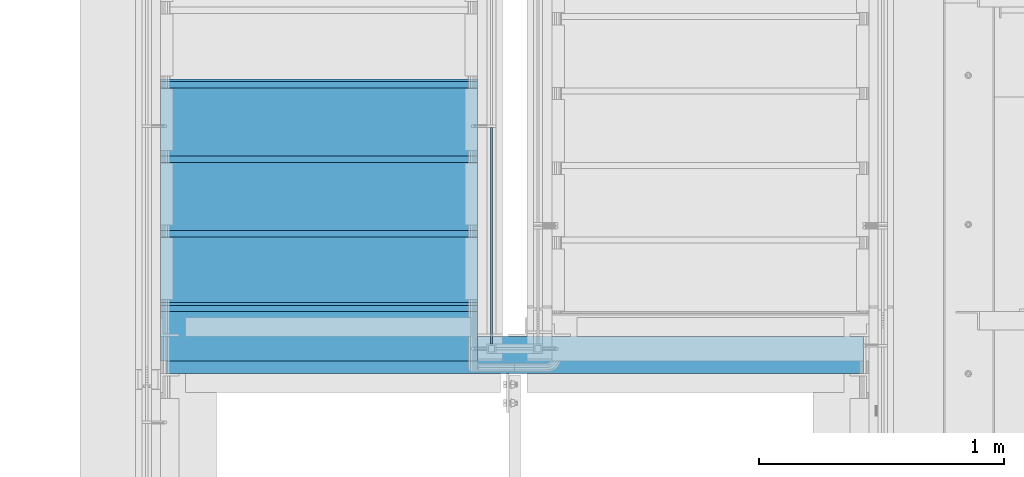
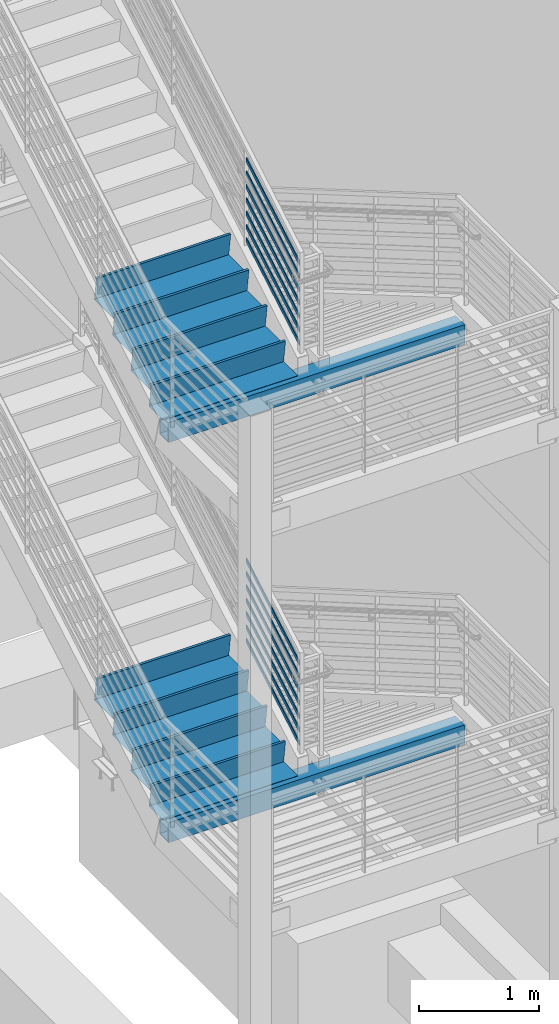
# One storey, part 753 of 1179: 14 members, 10 beams, 6 elements without a shape of their own.
"""IFC2X3 building model written with IfcOpenShell, lengths in millimetres."""

from ifc_helpers import new_model, si_unit, frame, origin_with_axes, place, context, subcontext, project, spatial, faceted_brep, material, type_object, element, aggregate, save


model = new_model("IFC2X3")

# Units and contexts
model_context = context("Model", 3, precision=1e-05, world=origin_with_axes())
body_context = subcontext(model_context, "Body", "Model", "MODEL_VIEW")
ifc_project = project(units=[si_unit("LENGTHUNIT", "METRE", prefix="MILLI"), si_unit("AREAUNIT", "SQUARE_METRE"), si_unit("VOLUMEUNIT", "CUBIC_METRE"), si_unit("MASSUNIT", "GRAM", prefix="KILO"), si_unit("TIMEUNIT", "SECOND"), si_unit("PLANEANGLEUNIT", "RADIAN"), si_unit("SOLIDANGLEUNIT", "STERADIAN"), si_unit("THERMODYNAMICTEMPERATUREUNIT", "DEGREE_CELSIUS"), si_unit("LUMINOUSINTENSITYUNIT", "LUMEN")], contexts=[model_context])

# Site, building, storey
site_placement = place(None, origin_with_axes())
site = spatial("IfcSite", under=ifc_project, at=site_placement, CompositionType="ELEMENT")
building_placement = place(site_placement, origin_with_axes())
building = spatial("IfcBuilding", under=site, at=building_placement, Name="Undefined", CompositionType="ELEMENT")
storey_placement = place(building_placement, origin_with_axes())
storey = spatial("IfcBuildingStorey", under=building, at=storey_placement, Name="Undefined", CompositionType="ELEMENT", Elevation=0.0)

# Assembly, members
assembly_1_placement = place(storey_placement, origin_with_axes())
assembly_1 = element("IfcElementAssembly", 1, at=assembly_1_placement, inside=storey, Name="GUARDRAIL", AssemblyPlace="NOTDEFINED", PredefinedType="RIGID_FRAME")
ifc_material_1 = material(Name="STEEL/A36")
member_type = type_object("IfcMemberType", PredefinedType="NOTDEFINED")
member_1_placement = place(assembly_1_placement, frame((-1847.85000153055, 32657.0650348949, 6932.20421216632), z_axis=(0.0, -0.503851349994406, 0.86379037799041), x_axis=(0.0, -0.86379037799041, -0.503851349994406)))
member_1 = element("IfcMember", 2, at=member_1_placement, type_object=member_type, material=ifc_material_1, Name="PLATE", context=body_context, shape_type="Brep", body=[
    faceted_brep([(27.7373273120902, 4.76250000000005, -19.0499999999865), (5.51349046009636, 4.76250000000005, 19.0499999999811), (1031.63336768552, 4.76250000000005, 19.0499999996719), (1053.85720453752, 4.76250000000005, -19.0500000002939), (5.51349046009636, -4.76250000000005, 19.0499999999811), (1031.63336768552, -4.76250000000005, 19.0499999996719), (27.7373273120902, -4.76250000000005, -19.0499999999865), (1053.85720453752, -4.76250000000005, -19.0500000002939)], [[[0, 1, 2, 3]], [[1, 4, 5, 2]], [[4, 6, 7, 5]], [[6, 0, 3, 7]], [[5, 7, 3, 2]], [[6, 4, 1, 0]]]),
])
member_2_placement = place(assembly_1_placement, frame((-1847.85000153055, 32657.0650348949, 7068.38772184206), z_axis=(0.0, -0.503851349994406, 0.86379037799041), x_axis=(0.0, -0.86379037799041, -0.503851349994406)))
member_2 = element("IfcMember", 3, at=member_2_placement, type_object=member_type, material=ifc_material_1, Name="PLATE", context=body_context, shape_type="Brep", body=[
    faceted_brep([(27.7373273120902, 4.76250000000005, -19.0499999999865), (5.51349046009636, 4.76250000000005, 19.0499999999811), (1031.63336768552, 4.76250000000005, 19.0499999996719), (1053.85720453752, 4.76250000000005, -19.0500000002939), (5.51349046009636, -4.76250000000005, 19.0499999999811), (1031.63336768552, -4.76250000000005, 19.0499999996719), (27.7373273120902, -4.76250000000005, -19.0499999999865), (1053.85720453752, -4.76250000000005, -19.0500000002939)], [[[0, 1, 2, 3]], [[1, 4, 5, 2]], [[4, 6, 7, 5]], [[6, 0, 3, 7]], [[5, 7, 3, 2]], [[6, 4, 1, 0]]]),
])
member_3_placement = place(assembly_1_placement, frame((-1847.85000153055, 32657.0650348948, 7204.57123151781), z_axis=(0.0, -0.503851349994406, 0.86379037799041), x_axis=(0.0, -0.86379037799041, -0.503851349994406)))
member_3 = element("IfcMember", 4, at=member_3_placement, type_object=member_type, material=ifc_material_1, Name="PLATE", context=body_context, shape_type="Brep", body=[
    faceted_brep([(27.7373273120902, 4.76250000000005, -19.0499999999865), (5.51349046009636, 4.76250000000005, 19.0499999999811), (1031.63336768552, 4.76250000000005, 19.0499999996719), (1053.85720453752, 4.76250000000005, -19.0500000002939), (5.51349046009636, -4.76250000000005, 19.0499999999811), (1031.63336768552, -4.76250000000005, 19.0499999996719), (27.7373273120902, -4.76250000000005, -19.0499999999865), (1053.85720453752, -4.76250000000005, -19.0500000002939)], [[[0, 1, 2, 3]], [[1, 4, 5, 2]], [[4, 6, 7, 5]], [[6, 0, 3, 7]], [[5, 7, 3, 2]], [[6, 4, 1, 0]]]),
])
member_4_placement = place(assembly_1_placement, frame((-1847.85000153055, 32657.0650348948, 7340.75474119355), z_axis=(0.0, -0.503851349994406, 0.86379037799041), x_axis=(0.0, -0.86379037799041, -0.503851349994406)))
member_4 = element("IfcMember", 5, at=member_4_placement, type_object=member_type, material=ifc_material_1, Name="PLATE", context=body_context, shape_type="Brep", body=[
    faceted_brep([(27.7373273120902, 4.76250000000005, -19.0499999999865), (5.51349046009636, 4.76250000000005, 19.0499999999811), (1031.63336768552, 4.76250000000005, 19.0499999996719), (1053.85720453752, 4.76250000000005, -19.0500000002939), (5.51349046009636, -4.76250000000005, 19.0499999999811), (1031.63336768552, -4.76250000000005, 19.0499999996719), (27.7373273120902, -4.76250000000005, -19.0499999999865), (1053.85720453752, -4.76250000000005, -19.0500000002939)], [[[0, 1, 2, 3]], [[1, 4, 5, 2]], [[4, 6, 7, 5]], [[6, 0, 3, 7]], [[5, 7, 3, 2]], [[6, 4, 1, 0]]]),
])
member_5_placement = place(assembly_1_placement, frame((-1847.85000153055, 32657.0650348949, 7476.93825086929), z_axis=(0.0, -0.503851349994406, 0.86379037799041), x_axis=(0.0, -0.86379037799041, -0.503851349994406)))
member_5 = element("IfcMember", 6, at=member_5_placement, type_object=member_type, material=ifc_material_1, Name="PLATE", context=body_context, shape_type="Brep", body=[
    faceted_brep([(27.7373273120902, 4.76250000000005, -19.0499999999865), (5.51349046009636, 4.76250000000005, 19.0499999999811), (1031.63336768552, 4.76250000000005, 19.0499999996719), (1053.85720453752, 4.76250000000005, -19.0500000002939), (5.51349046009636, -4.76250000000005, 19.0499999999811), (1031.63336768552, -4.76250000000005, 19.0499999996719), (27.7373273120902, -4.76250000000005, -19.0499999999865), (1053.85720453752, -4.76250000000005, -19.0500000002939)], [[[0, 1, 2, 3]], [[1, 4, 5, 2]], [[4, 6, 7, 5]], [[6, 0, 3, 7]], [[5, 7, 3, 2]], [[6, 4, 1, 0]]]),
])
member_6_placement = place(assembly_1_placement, frame((-1847.85000153055, 32657.065034895, 7613.12176054373), z_axis=(0.0, -0.503851349994406, 0.86379037799041), x_axis=(0.0, -0.86379037799041, -0.503851349994406)))
member_6 = element("IfcMember", 7, at=member_6_placement, type_object=member_type, material=ifc_material_1, Name="PLATE", context=body_context, shape_type="Brep", body=[
    faceted_brep([(27.7373273120902, 4.76250000000005, -19.0499999999865), (5.51349046009636, 4.76250000000005, 19.0499999999811), (1031.63336768552, 4.76250000000005, 19.0499999996719), (1053.85720453752, 4.76250000000005, -19.0500000002939), (5.51349046009636, -4.76250000000005, 19.0499999999811), (1031.63336768552, -4.76250000000005, 19.0499999996719), (27.7373273120902, -4.76250000000005, -19.0499999999865), (1053.85720453752, -4.76250000000005, -19.0500000002939)], [[[0, 1, 2, 3]], [[1, 4, 5, 2]], [[4, 6, 7, 5]], [[6, 0, 3, 7]], [[5, 7, 3, 2]], [[6, 4, 1, 0]]]),
])
member_7_placement = place(assembly_1_placement, frame((-1847.85000153055, 32657.0650348959, 7749.30527021945), z_axis=(0.0, -0.503851349994406, 0.86379037799041), x_axis=(0.0, -0.86379037799041, -0.503851349994406)))
member_7 = element("IfcMember", 8, at=member_7_placement, type_object=member_type, material=ifc_material_1, Name="PLATE", context=body_context, shape_type="Brep", body=[
    faceted_brep([(27.7373273120902, 4.76250000000005, -19.0499999999865), (5.51349046009636, 4.76250000000005, 19.0499999999811), (1031.63336768552, 4.76250000000005, 19.0499999996719), (1053.85720453752, 4.76250000000005, -19.0500000002939), (5.51349046009636, -4.76250000000005, 19.0499999999811), (1031.63336768552, -4.76250000000005, 19.0499999996719), (27.7373273120902, -4.76250000000005, -19.0499999999865), (1053.85720453752, -4.76250000000005, -19.0500000002939)], [[[0, 1, 2, 3]], [[1, 4, 5, 2]], [[4, 6, 7, 5]], [[6, 0, 3, 7]], [[5, 7, 3, 2]], [[6, 4, 1, 0]]]),
])
aggregate(assembly_1, [member_1, member_2, member_3, member_4, member_5, member_6, member_7])

assembly_2_placement = place(storey_placement, origin_with_axes())
assembly_2 = element("IfcElementAssembly", 9, at=assembly_2_placement, inside=storey, Name="GUARDRAIL", AssemblyPlace="NOTDEFINED", PredefinedType="RIGID_FRAME")
member_8_placement = place(assembly_2_placement, frame((-1847.85000076555, 32657.0119717504, 2855.03882129838), z_axis=(0.0, -0.501065882891537, 0.865409140812671), x_axis=(0.0, -0.86540914081267, -0.501065882891538)))
member_8 = element("IfcMember", 10, at=member_8_placement, type_object=member_type, material=ifc_material_1, Name="PLATE", context=body_context, shape_type="Brep", body=[
    faceted_brep([(27.5628128089447, 4.76250000000005, -19.0499999999756), (5.50317738577724, 4.76250000000005, 19.0499999999902), (1029.7056333605, 4.76250000000005, 19.0500000004522), (1051.76526878367, 4.76250000000005, -19.0499999995136), (5.50317738577724, -4.76250000000005, 19.0499999999902), (1029.7056333605, -4.76250000000005, 19.0500000004522), (27.5628128089447, -4.76250000000005, -19.0499999999756), (1051.76526878367, -4.76250000000005, -19.0499999995136)], [[[0, 1, 2, 3]], [[1, 4, 5, 2]], [[4, 6, 7, 5]], [[6, 0, 3, 7]], [[5, 7, 3, 2]], [[6, 4, 1, 0]]]),
])
member_9_placement = place(assembly_2_placement, frame((-1847.85000076555, 32657.0119717505, 2991.13924026293), z_axis=(0.0, -0.501065882891537, 0.865409140812671), x_axis=(0.0, -0.86540914081267, -0.501065882891538)))
member_9 = element("IfcMember", 11, at=member_9_placement, type_object=member_type, material=ifc_material_1, Name="PLATE", context=body_context, shape_type="Brep", body=[
    faceted_brep([(27.5628128089447, 4.76250000000005, -19.0499999999756), (5.50317738577724, 4.76250000000005, 19.0499999999902), (1029.7056333605, 4.76250000000005, 19.0500000004522), (1051.76526878367, 4.76250000000005, -19.0499999995136), (5.50317738577724, -4.76250000000005, 19.0499999999902), (1029.7056333605, -4.76250000000005, 19.0500000004522), (27.5628128089447, -4.76250000000005, -19.0499999999756), (1051.76526878367, -4.76250000000005, -19.0499999995136)], [[[0, 1, 2, 3]], [[1, 4, 5, 2]], [[4, 6, 7, 5]], [[6, 0, 3, 7]], [[5, 7, 3, 2]], [[6, 4, 1, 0]]]),
])
member_10_placement = place(assembly_2_placement, frame((-1847.85000076555, 32657.0119717504, 3127.2396592274), z_axis=(0.0, -0.501065882891537, 0.865409140812671), x_axis=(0.0, -0.86540914081267, -0.501065882891538)))
member_10 = element("IfcMember", 12, at=member_10_placement, type_object=member_type, material=ifc_material_1, Name="PLATE", context=body_context, shape_type="Brep", body=[
    faceted_brep([(27.5628128089447, 4.76250000000005, -19.0499999999756), (5.50317738577724, 4.76250000000005, 19.0499999999902), (1029.7056333605, 4.76250000000005, 19.0500000004522), (1051.76526878367, 4.76250000000005, -19.0499999995136), (5.50317738577724, -4.76250000000005, 19.0499999999902), (1029.7056333605, -4.76250000000005, 19.0500000004522), (27.5628128089447, -4.76250000000005, -19.0499999999756), (1051.76526878367, -4.76250000000005, -19.0499999995136)], [[[0, 1, 2, 3]], [[1, 4, 5, 2]], [[4, 6, 7, 5]], [[6, 0, 3, 7]], [[5, 7, 3, 2]], [[6, 4, 1, 0]]]),
])
member_11_placement = place(assembly_2_placement, frame((-1847.85000076555, 32657.0119717505, 3263.34007819193), z_axis=(0.0, -0.501065882891537, 0.865409140812671), x_axis=(0.0, -0.86540914081267, -0.501065882891538)))
member_11 = element("IfcMember", 13, at=member_11_placement, type_object=member_type, material=ifc_material_1, Name="PLATE", context=body_context, shape_type="Brep", body=[
    faceted_brep([(27.5628128089447, 4.76250000000005, -19.0499999999756), (5.50317738577724, 4.76250000000005, 19.0499999999902), (1029.7056333605, 4.76250000000005, 19.0500000004522), (1051.76526878367, 4.76250000000005, -19.0499999995136), (5.50317738577724, -4.76250000000005, 19.0499999999902), (1029.7056333605, -4.76250000000005, 19.0500000004522), (27.5628128089447, -4.76250000000005, -19.0499999999756), (1051.76526878367, -4.76250000000005, -19.0499999995136)], [[[0, 1, 2, 3]], [[1, 4, 5, 2]], [[4, 6, 7, 5]], [[6, 0, 3, 7]], [[5, 7, 3, 2]], [[6, 4, 1, 0]]]),
])
member_12_placement = place(assembly_2_placement, frame((-1847.85000076555, 32657.0119717505, 3399.44049715647), z_axis=(0.0, -0.501065882891537, 0.865409140812671), x_axis=(0.0, -0.86540914081267, -0.501065882891538)))
member_12 = element("IfcMember", 14, at=member_12_placement, type_object=member_type, material=ifc_material_1, Name="PLATE", context=body_context, shape_type="Brep", body=[
    faceted_brep([(27.5628128089447, 4.76250000000005, -19.0499999999756), (5.50317738577724, 4.76250000000005, 19.0499999999902), (1029.7056333605, 4.76250000000005, 19.0500000004522), (1051.76526878367, 4.76250000000005, -19.0499999995136), (5.50317738577724, -4.76250000000005, 19.0499999999902), (1029.7056333605, -4.76250000000005, 19.0500000004522), (27.5628128089447, -4.76250000000005, -19.0499999999756), (1051.76526878367, -4.76250000000005, -19.0499999995136)], [[[0, 1, 2, 3]], [[1, 4, 5, 2]], [[4, 6, 7, 5]], [[6, 0, 3, 7]], [[5, 7, 3, 2]], [[6, 4, 1, 0]]]),
])
member_13_placement = place(assembly_2_placement, frame((-1847.85000076555, 32657.0119717502, 3535.54091612093), z_axis=(0.0, -0.501065882891537, 0.865409140812671), x_axis=(0.0, -0.86540914081267, -0.501065882891538)))
member_13 = element("IfcMember", 15, at=member_13_placement, type_object=member_type, material=ifc_material_1, Name="PLATE", context=body_context, shape_type="Brep", body=[
    faceted_brep([(27.5628128089447, 4.76250000000005, -19.0499999999756), (5.50317738577724, 4.76250000000005, 19.0499999999902), (1029.7056333605, 4.76250000000005, 19.0500000004522), (1051.76526878367, 4.76250000000005, -19.0499999995136), (5.50317738577724, -4.76250000000005, 19.0499999999902), (1029.7056333605, -4.76250000000005, 19.0500000004522), (27.5628128089447, -4.76250000000005, -19.0499999999756), (1051.76526878367, -4.76250000000005, -19.0499999995136)], [[[0, 1, 2, 3]], [[1, 4, 5, 2]], [[4, 6, 7, 5]], [[6, 0, 3, 7]], [[5, 7, 3, 2]], [[6, 4, 1, 0]]]),
])
member_14_placement = place(assembly_2_placement, frame((-1847.85000076555, 32657.0119717489, 3671.64133508543), z_axis=(0.0, -0.501065882891537, 0.865409140812671), x_axis=(0.0, -0.86540914081267, -0.501065882891538)))
member_14 = element("IfcMember", 16, at=member_14_placement, type_object=member_type, material=ifc_material_1, Name="PLATE", context=body_context, shape_type="Brep", body=[
    faceted_brep([(27.5628128089447, 4.76250000000005, -19.0499999999756), (5.50317738577724, 4.76250000000005, 19.0499999999902), (1029.7056333605, 4.76250000000005, 19.0500000004522), (1051.76526878367, 4.76250000000005, -19.0499999995136), (5.50317738577724, -4.76250000000005, 19.0499999999902), (1029.7056333605, -4.76250000000005, 19.0500000004522), (27.5628128089447, -4.76250000000005, -19.0499999999756), (1051.76526878367, -4.76250000000005, -19.0499999995136)], [[[0, 1, 2, 3]], [[1, 4, 5, 2]], [[4, 6, 7, 5]], [[6, 0, 3, 7]], [[5, 7, 3, 2]], [[6, 4, 1, 0]]]),
])
aggregate(assembly_2, [member_8, member_9, member_10, member_11, member_12, member_13, member_14])

# Assembly, beams
assembly_3_placement = place(storey_placement, origin_with_axes())
assembly_3 = element("IfcElementAssembly", 17, at=assembly_3_placement, inside=storey, Name="STRINGER", AssemblyPlace="NOTDEFINED", PredefinedType="RIGID_FRAME")
beam_type_1 = type_object("IfcBeamType", PredefinedType="NOTDEFINED")
beam_1_placement = place(assembly_3_placement, frame((-2552.70000000075, 32829.5000007375, 2822.04583333393), z_axis=(1.0, 0.0, 0.0), x_axis=(0.0, -1.0, 0.0)))
beam_1 = element("IfcBeam", 18, at=beam_1_placement, type_object=beam_type_1, material=ifc_material_1, Name="TREAD", context=body_context, shape_type="Brep", body=[
    faceted_brep([(-5.47515810467303e-10, -1.58750000000146, -647.7), (-5.47515810467303e-10, -1.58750000000146, 647.7), (5.49334799870849e-10, 1.58749999999418, 647.7), (5.49334799870849e-10, 1.58749999999418, -647.7), (21.7353257776667, 1.58750000000009, 647.7), (21.7353257776667, 1.58750000000009, -647.7), (25.4000000001688, -1.58750000000009, -647.7), (25.4000000001688, -1.58750000000009, 647.7), (-10.9762326817727, 228.864583333333, 647.7), (-10.9762326817727, 228.864583333333, -647.7), (-7.31154422789405, 225.689583333333, -647.7), (-7.31154422789405, 225.689583333333, 647.7), (319.223767229007, 228.864583333333, 647.7), (319.223767229007, 228.864583333333, -647.7), (316.473021803613, 225.689583333333, -647.7), (316.473021803613, 225.689583333333, 647.7), (325.043366447484, 188.430492929979, 647.7), (325.043366447484, 188.430492929979, -647.7), (321.900749692417, 187.978182272578, 647.7), (321.900749692417, 187.978182272578, -647.7)], [[[0, 1, 2, 3]], [[3, 2, 4, 5]], [[1, 0, 6, 7]], [[5, 4, 8, 9]], [[7, 6, 10, 11]], [[9, 8, 12, 13]], [[11, 10, 14, 15]], [[13, 12, 16, 17]], [[12, 8, 4, 2, 1, 7, 11, 15, 18, 16]], [[15, 14, 19, 18]], [[14, 10, 6, 0, 3, 5, 9, 13, 17, 19]], [[18, 19, 17, 16]]]),
])
beam_2_placement = place(assembly_3_placement, frame((-2552.70000000079, 32524.7000008267, 2645.56875000059), z_axis=(1.0, 0.0, 0.0), x_axis=(0.0, -1.0, 0.0)))
beam_2 = element("IfcBeam", 19, at=beam_2_placement, type_object=beam_type_1, material=ifc_material_1, Name="TREAD", context=body_context, shape_type="Brep", body=[
    faceted_brep([(-5.47515810467303e-10, -1.58750000000146, -647.7), (-5.47515810467303e-10, -1.58750000000146, 647.7), (5.49334799870849e-10, 1.58749999999418, 647.7), (5.49334799870849e-10, 1.58749999999418, -647.7), (21.7353257776667, 1.58750000000009, 647.7), (21.7353257776667, 1.58750000000009, -647.7), (25.4000000001688, -1.58750000000009, -647.7), (25.4000000001688, -1.58750000000009, 647.7), (-10.9762326817727, 228.864583333333, 647.7), (-10.9762326817727, 228.864583333333, -647.7), (-7.31154422789405, 225.689583333333, -647.7), (-7.31154422789405, 225.689583333333, 647.7), (319.223767229007, 228.864583333333, 647.7), (319.223767229007, 228.864583333333, -647.7), (316.473021803613, 225.689583333333, -647.7), (316.473021803613, 225.689583333333, 647.7), (325.043366447484, 188.430492929979, 647.7), (325.043366447484, 188.430492929979, -647.7), (321.900749692417, 187.978182272578, 647.7), (321.900749692417, 187.978182272578, -647.7)], [[[0, 1, 2, 3]], [[3, 2, 4, 5]], [[1, 0, 6, 7]], [[5, 4, 8, 9]], [[7, 6, 10, 11]], [[9, 8, 12, 13]], [[11, 10, 14, 15]], [[13, 12, 16, 17]], [[12, 8, 4, 2, 1, 7, 11, 15, 18, 16]], [[15, 14, 19, 18]], [[14, 10, 6, 0, 3, 5, 9, 13, 17, 19]], [[18, 19, 17, 16]]]),
])
beam_3_placement = place(assembly_3_placement, frame((-2552.70000000083, 32219.9000009159, 2469.09166666726), z_axis=(1.0, 0.0, 0.0), x_axis=(0.0, -1.0, 0.0)))
beam_3 = element("IfcBeam", 20, at=beam_3_placement, type_object=beam_type_1, material=ifc_material_1, Name="TREAD", context=body_context, shape_type="Brep", body=[
    faceted_brep([(-5.47515810467303e-10, -1.58750000000146, -647.7), (-5.47515810467303e-10, -1.58750000000146, 647.7), (5.49334799870849e-10, 1.58749999999418, 647.7), (5.49334799870849e-10, 1.58749999999418, -647.7), (21.7353257776667, 1.58750000000009, 647.7), (21.7353257776667, 1.58750000000009, -647.7), (25.4000000001688, -1.58750000000009, -647.7), (25.4000000001688, -1.58750000000009, 647.7), (-10.9762326817727, 228.864583333333, 647.7), (-10.9762326817727, 228.864583333333, -647.7), (-7.31154422789405, 225.689583333333, -647.7), (-7.31154422789405, 225.689583333333, 647.7), (319.223767229007, 228.864583333333, 647.7), (319.223767229007, 228.864583333333, -647.7), (316.473021803613, 225.689583333333, -647.7), (316.473021803613, 225.689583333333, 647.7), (325.043366447484, 188.430492929979, 647.7), (325.043366447484, 188.430492929979, -647.7), (321.900749692417, 187.978182272578, 647.7), (321.900749692417, 187.978182272578, -647.7)], [[[0, 1, 2, 3]], [[3, 2, 4, 5]], [[1, 0, 6, 7]], [[5, 4, 8, 9]], [[7, 6, 10, 11]], [[9, 8, 12, 13]], [[11, 10, 14, 15]], [[13, 12, 16, 17]], [[12, 8, 4, 2, 1, 7, 11, 15, 18, 16]], [[15, 14, 19, 18]], [[14, 10, 6, 0, 3, 5, 9, 13, 17, 19]], [[18, 19, 17, 16]]]),
])

assembly_4_placement = place(storey_placement, origin_with_axes())
assembly_4 = element("IfcElementAssembly", 21, at=assembly_4_placement, inside=storey, Name="STRINGER", AssemblyPlace="NOTDEFINED", PredefinedType="RIGID_FRAME")
beam_type_2 = type_object("IfcBeamType", PredefinedType="NOTDEFINED")
beam_4_placement = place(assembly_4_placement, frame((-2552.69999999752, 32829.5000017509, 6900.86249999919), z_axis=(1.0, 0.0, 0.0), x_axis=(0.0, -1.0, 0.0)))
beam_4 = element("IfcBeam", 22, at=beam_4_placement, type_object=beam_type_2, material=ifc_material_1, Name="TREAD", context=body_context, shape_type="Brep", body=[
    faceted_brep([(-5.47515810467303e-10, -1.58750000000146, -647.7), (-5.47515810467303e-10, -1.58750000000146, 647.7), (5.49334799870849e-10, 1.58749999999418, 647.7), (5.49334799870849e-10, 1.58749999999418, -647.7), (21.7391942417962, 1.58749999999964, 647.7), (21.7391942417962, 1.58749999999964, -647.7), (25.4000000001688, -1.58750000000009, -647.7), (25.4000000001688, -1.58750000000009, 647.7), (-10.9179486153444, 230.1875, 647.7), (-10.9179486153444, 230.1875, -647.7), (-7.25714285782306, 227.012500000001, -647.7), (-7.25714285782306, 227.012500000001, 647.7), (319.2820511338, 230.1875, 647.7), (319.2820511338, 230.1875, -647.7), (316.528388233419, 227.012500000001, -647.7), (316.528388233419, 227.012500000001, 647.7), (325.059631548502, 189.744437097058, 647.7), (325.059631548502, 189.744437097058, -647.7), (321.916541906132, 189.295424291005, 647.7), (321.916541906132, 189.295424291005, -647.7)], [[[0, 1, 2, 3]], [[3, 2, 4, 5]], [[1, 0, 6, 7]], [[5, 4, 8, 9]], [[7, 6, 10, 11]], [[9, 8, 12, 13]], [[11, 10, 14, 15]], [[13, 12, 16, 17]], [[12, 8, 4, 2, 1, 7, 11, 15, 18, 16]], [[15, 14, 19, 18]], [[14, 10, 6, 0, 3, 5, 9, 13, 17, 19]], [[18, 19, 17, 16]]]),
])
beam_5_placement = place(assembly_4_placement, frame((-2552.69999999732, 32524.7000020029, 6723.06249999919), z_axis=(1.0, 0.0, 0.0), x_axis=(0.0, -1.0, 0.0)))
beam_5 = element("IfcBeam", 23, at=beam_5_placement, type_object=beam_type_2, material=ifc_material_1, Name="TREAD", context=body_context, shape_type="Brep", body=[
    faceted_brep([(-5.47515810467303e-10, -1.58750000000146, -647.7), (-5.47515810467303e-10, -1.58750000000146, 647.7), (5.49334799870849e-10, 1.58749999999418, 647.7), (5.49334799870849e-10, 1.58749999999418, -647.7), (21.7391942417962, 1.58749999999964, 647.7), (21.7391942417962, 1.58749999999964, -647.7), (25.4000000001688, -1.58750000000009, -647.7), (25.4000000001688, -1.58750000000009, 647.7), (-10.9179486153444, 230.1875, 647.7), (-10.9179486153444, 230.1875, -647.7), (-7.25714285782306, 227.012500000001, -647.7), (-7.25714285782306, 227.012500000001, 647.7), (319.2820511338, 230.1875, 647.7), (319.2820511338, 230.1875, -647.7), (316.528388233419, 227.012500000001, -647.7), (316.528388233419, 227.012500000001, 647.7), (325.059631548502, 189.744437097058, 647.7), (325.059631548502, 189.744437097058, -647.7), (321.916541906132, 189.295424291005, 647.7), (321.916541906132, 189.295424291005, -647.7)], [[[0, 1, 2, 3]], [[3, 2, 4, 5]], [[1, 0, 6, 7]], [[5, 4, 8, 9]], [[7, 6, 10, 11]], [[9, 8, 12, 13]], [[11, 10, 14, 15]], [[13, 12, 16, 17]], [[12, 8, 4, 2, 1, 7, 11, 15, 18, 16]], [[15, 14, 19, 18]], [[14, 10, 6, 0, 3, 5, 9, 13, 17, 19]], [[18, 19, 17, 16]]]),
])
beam_6_placement = place(assembly_4_placement, frame((-2552.69999999711, 32219.9000022549, 6545.26249999919), z_axis=(1.0, 0.0, 0.0), x_axis=(0.0, -1.0, 0.0)))
beam_6 = element("IfcBeam", 24, at=beam_6_placement, type_object=beam_type_2, material=ifc_material_1, Name="TREAD", context=body_context, shape_type="Brep", body=[
    faceted_brep([(-5.47515810467303e-10, -1.58750000000146, -647.7), (-5.47515810467303e-10, -1.58750000000146, 647.7), (5.49334799870849e-10, 1.58749999999418, 647.7), (5.49334799870849e-10, 1.58749999999418, -647.7), (21.7391942417962, 1.58749999999964, 647.7), (21.7391942417962, 1.58749999999964, -647.7), (25.4000000001688, -1.58750000000009, -647.7), (25.4000000001688, -1.58750000000009, 647.7), (-10.9179486153444, 230.1875, 647.7), (-10.9179486153444, 230.1875, -647.7), (-7.25714285782306, 227.012500000001, -647.7), (-7.25714285782306, 227.012500000001, 647.7), (319.2820511338, 230.1875, 647.7), (319.2820511338, 230.1875, -647.7), (316.528388233419, 227.012500000001, -647.7), (316.528388233419, 227.012500000001, 647.7), (325.059631548502, 189.744437097058, 647.7), (325.059631548502, 189.744437097058, -647.7), (321.916541906132, 189.295424291005, 647.7), (321.916541906132, 189.295424291005, -647.7)], [[[0, 1, 2, 3]], [[3, 2, 4, 5]], [[1, 0, 6, 7]], [[5, 4, 8, 9]], [[7, 6, 10, 11]], [[9, 8, 12, 13]], [[11, 10, 14, 15]], [[13, 12, 16, 17]], [[12, 8, 4, 2, 1, 7, 11, 15, 18, 16]], [[15, 14, 19, 18]], [[14, 10, 6, 0, 3, 5, 9, 13, 17, 19]], [[18, 19, 17, 16]]]),
])

# Assembly, beam
assembly_5_placement = place(storey_placement, origin_with_axes())
assembly_5 = element("IfcElementAssembly", 25, at=assembly_5_placement, inside=storey, Name="BEAM", AssemblyPlace="NOTDEFINED", PredefinedType="RIGID_FRAME")
ifc_material_2 = material()
beam_type_3 = type_object("IfcBeamType", Name="HSS8X6X3/8", PredefinedType="NOTDEFINED")
beam_7_placement = place(assembly_5_placement, frame((-3187.70000000007, 31711.9, 6035.67499999882), z_axis=(0.0, 0.0, 1.0), x_axis=(1.0, 0.0, 0.0)))
beam_7 = element("IfcBeam", 26, at=beam_7_placement, type_object=beam_type_3, material=ifc_material_2, Name="BEAM", ObjectType="HSS8X6X3/8", context=body_context, shape_type="Brep", body=[
    faceted_brep([(9.52500000002851, 66.6750000000029, -92.0750000000025), (9.52500000002851, -66.6750000000029, -92.0750000000025), (2860.67499925713, -66.6749999999993, -92.0749999999998), (2860.67499925713, 66.6749999999993, -92.0749999999998), (9.52499999997079, -66.6750000000029, 92.074999999998), (2860.67499925713, -66.6749999999993, 92.0749999999998), (9.52499999997079, 66.6750000000029, 92.074999999998), (2860.67499925713, 66.6749999999993, 92.0749999999998), (9.52500000003153, 76.1999999999971, -101.600000000002), (9.52499999996778, 76.1999999999971, 101.599999999998), (2860.67499925713, 76.2000000000007, 101.6), (2860.67499925713, 76.2000000000007, -101.6), (9.52499999996778, -76.1999999999971, 101.599999999998), (2860.67499925713, -76.2000000000007, 101.6), (9.52500000003153, -76.1999999999971, -101.600000000002), (2860.67499925713, -76.2000000000007, -101.6)], [[[0, 1, 2, 3]], [[1, 4, 5, 2]], [[4, 6, 7, 5]], [[6, 0, 3, 7]], [[8, 9, 10, 11]], [[9, 12, 13, 10]], [[12, 14, 15, 13]], [[14, 8, 11, 15]], [[13, 15, 11, 10], [5, 7, 3, 2]], [[14, 12, 9, 8], [6, 4, 1, 0]]]),
])
aggregate(assembly_5, [beam_7])

assembly_6_placement = place(storey_placement, origin_with_axes())
assembly_6 = element("IfcElementAssembly", 27, at=assembly_6_placement, inside=storey, Name="BEAM", AssemblyPlace="NOTDEFINED", PredefinedType="RIGID_FRAME")
beam_8_placement = place(assembly_6_placement, frame((-3187.70000000014, 31711.9, 1962.1500000003), z_axis=(0.0, 0.0, 1.0), x_axis=(1.0, 0.0, 0.0)))
beam_8 = element("IfcBeam", 28, at=beam_8_placement, type_object=beam_type_3, material=ifc_material_2, Name="BEAM", ObjectType="HSS8X6X3/8", context=body_context, shape_type="Brep", body=[
    faceted_brep([(9.52500000002851, 66.6750000000029, -92.0750000000025), (9.52500000002851, -66.6750000000029, -92.0750000000025), (2860.67499925713, -66.6749999999993, -92.0749999999998), (2860.67499925713, 66.6749999999993, -92.0749999999998), (9.52499999997079, -66.6750000000029, 92.074999999998), (2860.67499925713, -66.6749999999993, 92.0749999999998), (9.52499999997079, 66.6750000000029, 92.074999999998), (2860.67499925713, 66.6749999999993, 92.0749999999998), (9.52500000003153, 76.1999999999971, -101.600000000002), (9.52499999996778, 76.1999999999971, 101.599999999998), (2860.67499925713, 76.2000000000007, 101.6), (2860.67499925713, 76.2000000000007, -101.6), (9.52499999996778, -76.1999999999971, 101.599999999998), (2860.67499925713, -76.2000000000007, 101.6), (9.52500000003153, -76.1999999999971, -101.600000000002), (2860.67499925713, -76.2000000000007, -101.6)], [[[0, 1, 2, 3]], [[1, 4, 5, 2]], [[4, 6, 7, 5]], [[6, 0, 3, 7]], [[8, 9, 10, 11]], [[9, 12, 13, 10]], [[12, 14, 15, 13]], [[14, 8, 11, 15]], [[13, 15, 11, 10], [5, 7, 3, 2]], [[14, 12, 9, 8], [6, 4, 1, 0]]]),
])
aggregate(assembly_6, [beam_8])

# Beam
beam_type_4 = type_object("IfcBeamType", PredefinedType="NOTDEFINED")
beam_9_placement = place(assembly_4_placement, frame((-2552.69999999678, 31915.1000025094, 6367.46249999964), z_axis=(1.0, 0.0, 0.0), x_axis=(0.0, -1.0, 0.0)))
beam_9 = element("IfcBeam", 29, at=beam_9_placement, type_object=beam_type_4, material=ifc_material_1, Name="TREAD", context=body_context, shape_type="Brep", body=[
    faceted_brep([(-5.47515810467303e-10, -1.58750000000146, -647.7), (-5.47515810467303e-10, -1.58750000000146, 647.7), (5.49334799870849e-10, 1.58749999999418, 647.7), (5.49334799870849e-10, 1.58749999999418, -647.7), (21.7319976818617, 1.58749999998054, 647.7), (21.7319976818617, 1.58749999998054, -647.7), (25.4000000001688, -1.58750000000009, -647.7), (25.4000000001688, -1.58750000000009, 647.7), (-11.3787166040602, 230.187500000011, 647.7), (-11.3787166040602, 230.187500000011, -647.7), (-7.71071428356299, 227.012500000008, -647.7), (-7.71071428356299, 227.012500000008, 647.7), (228.599999999795, 230.187499999792, 647.7), (228.599999999795, 230.187499999792, -647.7), (228.599999999795, 227.012499999792, 647.7), (228.599999999795, 227.012499999792, -647.7)], [[[0, 1, 2, 3]], [[3, 2, 4, 5]], [[1, 0, 6, 7]], [[5, 4, 8, 9]], [[7, 6, 10, 11]], [[9, 8, 12, 13]], [[8, 4, 2, 1, 7, 11, 14, 12]], [[11, 10, 15, 14]], [[10, 6, 0, 3, 5, 9, 13, 15]], [[14, 15, 13, 12]]]),
])

aggregate(assembly_4, [beam_4, beam_5, beam_6, beam_9])

beam_type_5 = type_object("IfcBeamType", PredefinedType="NOTDEFINED")
beam_10_placement = place(assembly_3_placement, frame((-2552.70000000101, 31915.1000010028, 2292.61458333386), z_axis=(1.0, 0.0, 0.0), x_axis=(0.0, -1.0, 0.0)))
beam_10 = element("IfcBeam", 30, at=beam_10_placement, type_object=beam_type_5, material=ifc_material_1, Name="TREAD", context=body_context, shape_type="Brep", body=[
    faceted_brep([(-5.47515810467303e-10, -1.58750000000146, -647.7), (-5.47515810467303e-10, -1.58750000000146, 647.7), (5.49334799870849e-10, 1.58749999999418, 647.7), (5.49334799870849e-10, 1.58749999999418, -647.7), (21.728003605589, 1.58749999999009, 647.7), (21.728003605589, 1.58749999999009, -647.7), (25.4000000001688, -1.58750000000009, -647.7), (25.4000000001688, -1.58750000000009, 647.7), (-11.4024311771245, 228.600000000005, 647.7), (-11.4024311771245, 228.600000000005, -647.7), (-7.73043478508043, 225.425000000004, -647.7), (-7.73043478508043, 225.425000000004, 647.7), (228.599999999897, 228.599999999896, 647.7), (228.599999999897, 228.599999999896, -647.7), (228.599999999897, 225.424999999896, 647.7), (228.599999999897, 225.424999999896, -647.7)], [[[0, 1, 2, 3]], [[3, 2, 4, 5]], [[1, 0, 6, 7]], [[5, 4, 8, 9]], [[7, 6, 10, 11]], [[9, 8, 12, 13]], [[8, 4, 2, 1, 7, 11, 14, 12]], [[11, 10, 15, 14]], [[10, 6, 0, 3, 5, 9, 13, 15]], [[14, 15, 13, 12]]]),
])

aggregate(assembly_3, [beam_1, beam_2, beam_3, beam_10])

save(model, "model.ifc")
